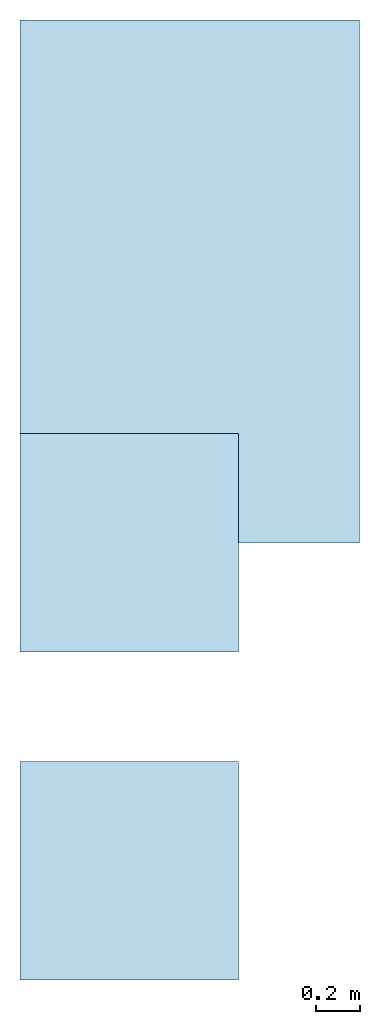
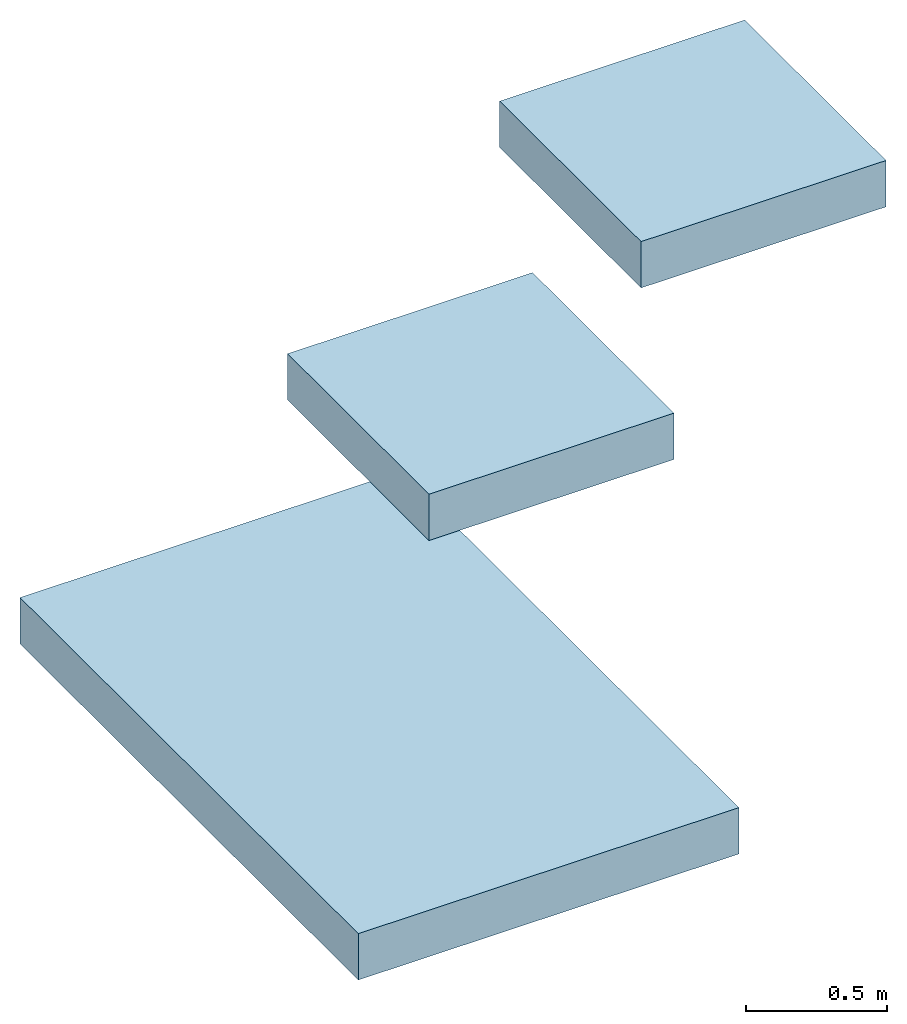
# One storey: 3 slabs.
"""IFC4 building model written with IfcOpenShell, lengths in metres."""

import ifcopenshell
import ifcopenshell.guid

model = None  # the IFC model being written
_history = None  # IfcOwnerHistory: only IFC2X3 demands one
_inside = {}  # id of a spatial element -> (the spatial element, [elements in it])
_under = {}  # id of a project, library or spatial element -> (it, [spatial elements below it])
_declared = {}  # id of a project -> (the project, [libraries it declares])
_typed = {}  # id of a type object -> (the type object, [elements of that type])
_made_of = {}  # id of a material, layer set ... -> (it, [elements and type objects made of it])


def new_model(schema):
    """Start an empty IFC model of exactly this schema.

    Asked for "IFC4X3", IfcOpenShell would pick the latest addendum, in which some entities
    have other attributes; the version numbers below select the first issue.
    IFC2X3 requires an IfcOwnerHistory on every rooted entity: one is made here for all.
    """
    global model, _history
    if schema == "IFC4X3":
        model = ifcopenshell.file(schema_version=(4, 3, 0, 0))
    else:
        model = ifcopenshell.file(schema=schema)
    _inside.clear()
    _under.clear()
    _declared.clear()
    _typed.clear()
    _made_of.clear()
    _history = None
    if model.schema == "IFC2X3":
        org = make("IfcOrganization", Name="unknown")
        user = make(
            "IfcPersonAndOrganization",
            ThePerson=make("IfcPerson", FamilyName="unknown"),
            TheOrganization=org,
        )
        app = make(
            "IfcApplication",
            ApplicationDeveloper=org,
            Version="unknown",
            ApplicationFullName="unknown",
            ApplicationIdentifier="unknown",
        )
        _history = make(
            "IfcOwnerHistory",
            OwningUser=user,
            OwningApplication=app,
            ChangeAction="ADDED",
            CreationDate=0,
        )
    return model


def make(cls, **values):
    """One entity of the class cls with the attributes given. An attribute that is None is left unset."""
    return model.create_entity(
        cls, **{name: value for name, value in values.items() if value is not None}
    )


def entity(cls, *values):
    """Any entity or typed value of the class cls, its attributes in the order of the schema. None: left unset."""
    e = model.create_entity(cls)
    for i, value in enumerate(values):
        if value is not None:
            e[i] = value
    return e


def rooted(cls, **values):
    """An entity with a GlobalId (a new one), such as an element, a storey or a relation."""
    return make(cls, GlobalId=ifcopenshell.guid.new(), OwnerHistory=_history, **values)


def si_unit(unit_type, name, prefix=None):
    """IfcSIUnit, for example si_unit("LENGTHUNIT", "METRE", prefix="MILLI")."""
    return make("IfcSIUnit", UnitType=unit_type, Prefix=prefix, Name=name)


def converted_unit(unit_type, name, factor, base, dimensions=None, offset=None):
    """IfcConversionBasedUnit, such as the inch: factor (a typed value) times the base unit."""
    return make(
        "IfcConversionBasedUnit"
        if offset is None
        else "IfcConversionBasedUnitWithOffset",
        ConversionOffset=offset,
        Dimensions=None
        if dimensions is None
        else entity("IfcDimensionalExponents", *dimensions),
        UnitType=unit_type,
        Name=name,
        ConversionFactor=make(
            "IfcMeasureWithUnit", ValueComponent=factor, UnitComponent=base
        ),
    )


def assignment(units):
    """IfcUnitAssignment: the units of a project."""
    return None if units is None else make("IfcUnitAssignment", Units=units)


def point(xyz):
    """IfcCartesianPoint."""
    return None if xyz is None else make("IfcCartesianPoint", Coordinates=xyz)


def direction(xyz):
    """IfcDirection."""
    return None if xyz is None else make("IfcDirection", DirectionRatios=xyz)


def frame(location, z_axis=None, x_axis=None):
    """IfcAxis2Placement3D, a coordinate frame: its origin and axes. An axis left out is left unset."""
    return make(
        "IfcAxis2Placement3D",
        Location=point(location),
        Axis=direction(z_axis),
        RefDirection=direction(x_axis),
    )


def frame_2d(location, x_axis=None):
    """IfcAxis2Placement2D, a coordinate frame in the plane: its origin and x axis."""
    return make(
        "IfcAxis2Placement2D", Location=point(location), RefDirection=direction(x_axis)
    )


def origin_with_axes():
    """The frame at (0, 0, 0) with the z axis (0, 0, 1) and the x axis (1, 0, 0) written out."""
    return frame((0.0, 0.0, 0.0), z_axis=(0.0, 0.0, 1.0), x_axis=(1.0, 0.0, 0.0))


def origin_2d_with_axis():
    """The frame at (0, 0) in the plane with the x axis (1, 0) written out."""
    return frame_2d((0.0, 0.0), x_axis=(1.0, 0.0))


def place(relative_to, where):
    """IfcLocalPlacement: puts the frame where relative to a parent placement (None: the world)."""
    return make(
        "IfcLocalPlacement", PlacementRelTo=relative_to, RelativePlacement=where
    )


def context(
    kind, dimensions, precision=None, world=None, true_north=None, identifier=None
):
    """IfcGeometricRepresentationContext, for example the 3D "Model" context."""
    return make(
        "IfcGeometricRepresentationContext",
        ContextIdentifier=identifier,
        ContextType=kind,
        CoordinateSpaceDimension=dimensions,
        Precision=precision,
        WorldCoordinateSystem=world,
        TrueNorth=true_north,
    )


def subcontext(parent, identifier, kind, view, scale=None):
    """IfcGeometricRepresentationSubContext, for example "Body" below "Model"."""
    return make(
        "IfcGeometricRepresentationSubContext",
        ContextIdentifier=identifier,
        ContextType=kind,
        ParentContext=parent,
        TargetScale=scale,
        TargetView=view,
    )


def project(units=None, contexts=None):
    """IfcProject with its units and contexts."""
    return rooted(
        "IfcProject",
        Name="project",
        RepresentationContexts=contexts,
        UnitsInContext=assignment(units),
    )


def spatial(cls, under=None, at=None, **own):
    """A site, building, storey or space (cls), placed at a placement, below another one or the project."""
    s = rooted(cls, ObjectPlacement=at, **own)
    if under is not None:
        _under.setdefault(under.id(), (under, []))[1].append(s)
    return s


def point_list(points):
    """IfcCartesianPointList2D or 3D."""
    cls = (
        "IfcCartesianPointList2D" if len(points[0]) == 2 else "IfcCartesianPointList3D"
    )
    return make(cls, CoordList=points)


def line(*indices):
    """IfcLineIndex: a straight run through numbered points of an indexed curve."""
    return model.create_entity("IfcLineIndex", indices)


def indexed_curve(points, segments=None, self_intersect=None):
    """IfcIndexedPolyCurve: lines and arcs through numbered points (the first is 1)."""
    return make(
        "IfcIndexedPolyCurve",
        Points=point_list(points),
        Segments=segments,
        SelfIntersect=self_intersect,
    )


def outline(outer, holes=None, kind="AREA"):
    """IfcArbitraryClosedProfileDef: a profile drawn as a closed curve; with holes, ...WithVoids."""
    if holes is None:
        return make("IfcArbitraryClosedProfileDef", ProfileType=kind, OuterCurve=outer)
    return make(
        "IfcArbitraryProfileDefWithVoids",
        ProfileType=kind,
        OuterCurve=outer,
        InnerCurves=holes,
    )


def extrude(swept, where, along, depth):
    """IfcExtrudedAreaSolid: the profile swept, set in the frame where, extruded along a direction by depth."""
    return make(
        "IfcExtrudedAreaSolid",
        SweptArea=swept,
        Position=where,
        ExtrudedDirection=direction(along),
        Depth=depth,
    )


def shape(context_of_items, identifier, shape_type, items):
    """IfcShapeRepresentation: the items that make up one representation, for example the "Body"."""
    return make(
        "IfcShapeRepresentation",
        ContextOfItems=context_of_items,
        RepresentationIdentifier=identifier,
        RepresentationType=shape_type,
        Items=items,
    )


def material(Name=None, Category=None):
    """IfcMaterial."""
    return make("IfcMaterial", Name=Name, Category=Category)


def layer(
    of_material, thickness, ventilated=None, Name=None, Category=None, Priority=None
):
    """IfcMaterialLayer: one layer of a wall or slab, of a material (None: an air gap)."""
    return make(
        "IfcMaterialLayer",
        Material=of_material,
        LayerThickness=thickness,
        IsVentilated=ventilated,
        Name=Name,
        Category=Category,
        Priority=Priority,
    )


def layer_set(layers, Name=None):
    """IfcMaterialLayerSet."""
    return make("IfcMaterialLayerSet", MaterialLayers=layers, LayerSetName=Name)


def layer_usage(for_layer_set, set_direction, sense, offset, extent=None):
    """IfcMaterialLayerSetUsage: how a layer set lies in its element."""
    return make(
        "IfcMaterialLayerSetUsage",
        ForLayerSet=for_layer_set,
        LayerSetDirection=set_direction,
        DirectionSense=sense,
        OffsetFromReferenceLine=offset,
        ReferenceExtent=extent,
    )


def made_of(thing, what):
    """Note that an element or type object is made of a material, layer set ...; save() writes the relation."""
    if what is not None:
        _made_of.setdefault(what.id(), (what, []))[1].append(thing)
    return thing


def type_object(cls, material=None, **own):
    """A type object (cls), such as IfcWallType, which elements share."""
    return made_of(rooted(cls, **own), material)


def element(
    cls,
    number,
    at=None,
    inside=None,
    cuts=None,
    type_object=None,
    material=None,
    context=None,
    identifier="Body",
    shape_type=None,
    held_by="IfcProductDefinitionShape",
    body=None,
    shapes=None,
    **own,
):
    """One element of the class cls, such as IfcWall. Its Tag is "e" and its number.

    at: its placement. inside: the storey or other place that contains it. cuts: it is an
    opening in that element (IfcRelVoidsElement). A single representation is given by context,
    identifier, shape_type and body (its items); several are given by shapes. held_by: the class
    of the entity that holds the representations. save() writes the other relations.
    """
    e = rooted(cls, Tag="e%d" % number, ObjectPlacement=at, **own)
    if body is not None:
        shapes = [shape(context, identifier, shape_type, body)]
    if shapes is not None:
        e.Representation = make(held_by, Representations=shapes)
    if inside is not None:
        _inside.setdefault(inside.id(), (inside, []))[1].append(e)
    if cuts is not None:
        rooted(
            "IfcRelVoidsElement", RelatingBuildingElement=cuts, RelatedOpeningElement=e
        )
    if type_object is not None:
        _typed.setdefault(type_object.id(), (type_object, []))[1].append(e)
    return made_of(e, material)


def aggregate(whole, parts):
    """IfcRelAggregates: a whole, such as a stair, and the parts it consists of."""
    return rooted("IfcRelAggregates", RelatingObject=whole, RelatedObjects=parts)


def save(model, path):
    """Write the relations noted so far, then the file.

    IfcRelAggregates (storeys below a building ...), IfcRelContainedInSpatialStructure (elements
    in a storey), IfcRelDefinesByType, IfcRelAssociatesMaterial and IfcRelDeclares: one each for
    every whole, place, type object, material and project.
    """
    for whole, parts in _under.values():
        aggregate(whole, parts)
    for where, things in _inside.values():
        rooted(
            "IfcRelContainedInSpatialStructure",
            RelatedElements=things,
            RelatingStructure=where,
        )
    for kind, things in _typed.values():
        rooted("IfcRelDefinesByType", RelatedObjects=things, RelatingType=kind)
    for what, things in _made_of.values():
        rooted("IfcRelAssociatesMaterial", RelatedObjects=things, RelatingMaterial=what)
    for by, libraries in _declared.values():
        rooted("IfcRelDeclares", RelatingContext=by, RelatedDefinitions=libraries)
    model.write(path)


model = new_model("IFC4")

# Units and contexts
model_context = context("Model", 3, precision=1e-05, world=origin_with_axes())
plan_context = context("Plan", 2, precision=1e-05, world=origin_2d_with_axis())
body_context = subcontext(model_context, "Body", "Model", "MODEL_VIEW")
ifc_project = project(units=[si_unit("VOLUMEUNIT", "CUBIC_METRE"), si_unit("LENGTHUNIT", "METRE"), converted_unit("PLANEANGLEUNIT", "degree", entity("IfcReal", 0.0174532925199433), si_unit("PLANEANGLEUNIT", "RADIAN"), dimensions=[0, 0, 0, 0, 0, 0, 0]), si_unit("AREAUNIT", "SQUARE_METRE")], contexts=[model_context, plan_context])

# Site, building, storey
site_placement = place(None, origin_with_axes())
site = spatial("IfcSite", under=ifc_project, at=site_placement)
building_placement = place(site_placement, origin_with_axes())
building = spatial("IfcBuilding", under=site, at=building_placement, Name="Building")
storey_placement = place(building_placement, origin_with_axes())
storey = spatial("IfcBuildingStorey", under=building, at=storey_placement, Name="Storey")

# Slabs
ifc_material = material(Name="C 25/30", Category="Beton")
ifc_layer = layer(ifc_material, 0.200000002980232)
ifc_layer_set = layer_set([ifc_layer], Name="Beton Decke 20 cm")
ifc_layer_usage_1 = layer_usage(ifc_layer_set, "AXIS3", "POSITIVE", 0.0)
slab_type = type_object("IfcSlabType", Name="Beton 20 cm", PredefinedType="NOTDEFINED", material=ifc_layer_set)
slab_1_placement = place(storey_placement, frame((0.0, 3.0, -0.200000002980232), z_axis=(0.0, 0.0, 1.0), x_axis=(1.0, 0.0, 0.0)))
element("IfcSlab", 1, at=slab_1_placement, inside=storey, type_object=slab_type, material=ifc_layer_usage_1, context=body_context, shape_type="SweptSolid", body=[
    extrude(outline(indexed_curve([(1.55390977859497, 1.39235305786133), (1.55390977859497, -1.0), (0.0, -1.0), (0.0, 1.39235305786133)], segments=[line(3, 2), line(2, 1), line(1, 4), line(4, 3)], self_intersect=False)), None, (0.0, 0.0, 1.0), 0.200000002980232),
])
ifc_layer_usage_2 = layer_usage(ifc_layer_set, "AXIS3", "POSITIVE", 0.0)
slab_2_placement = place(storey_placement, frame((0.0, 1.5, 2.0), z_axis=(0.0, 0.0, 1.0), x_axis=(1.0, 0.0, 0.0)))
element("IfcSlab", 2, at=slab_2_placement, inside=storey, type_object=slab_type, material=ifc_layer_usage_2, Name="Floor", PredefinedType="FLOOR", context=body_context, shape_type="SweptSolid", body=[
    extrude(outline(indexed_curve([(0.0, 0.0), (1.0, 0.0), (1.0, 1.0), (0.0, 1.0), (0.0, 0.0)])), None, (0.0, 0.0, 1.0), 0.200000002980232),
])
ifc_layer_usage_3 = layer_usage(ifc_layer_set, "AXIS3", "POSITIVE", 0.0)
slab_3_placement = place(storey_placement, frame((0.0, 0.0, 4.0), z_axis=(0.0, 0.0, 1.0), x_axis=(1.0, 0.0, 0.0)))
element("IfcSlab", 3, at=slab_3_placement, inside=storey, type_object=slab_type, material=ifc_layer_usage_3, Name="roof", PredefinedType="ROOF", context=body_context, shape_type="SweptSolid", body=[
    extrude(outline(indexed_curve([(0.0, 0.0), (1.0, 0.0), (1.0, 1.0), (0.0, 1.0), (0.0, 0.0)])), None, (0.0, 0.0, 1.0), 0.200000002980232),
])

save(model, "model.ifc")
